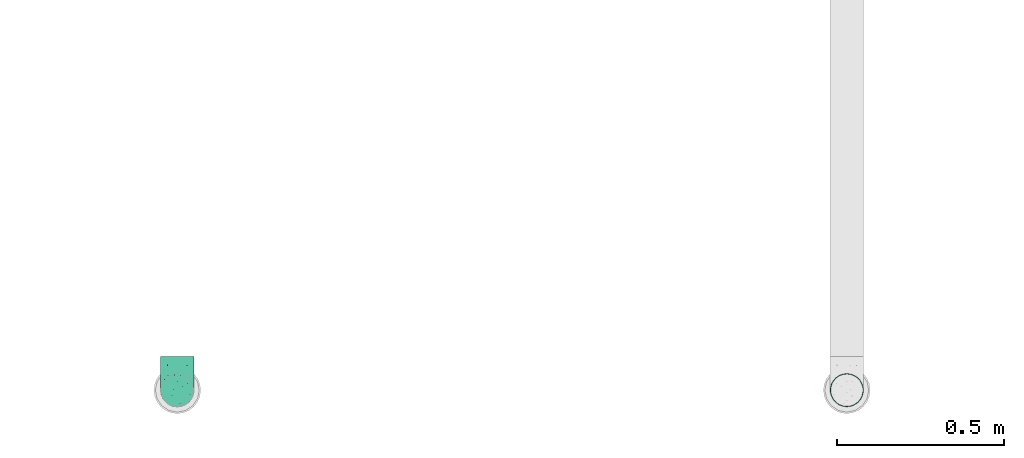
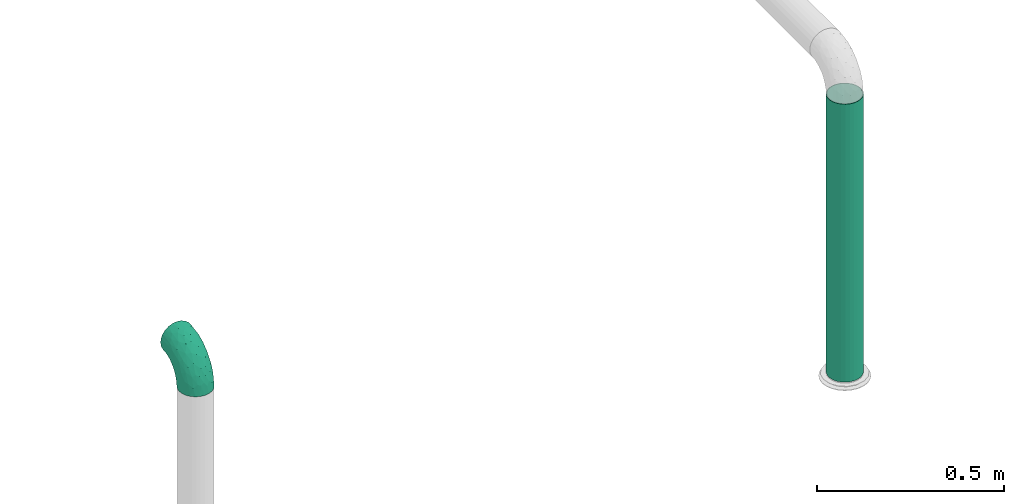
# One storey, part 19 of 103: 1 flow fitting, 1 flow segment.
"""IFC2X3 building model written with IfcOpenShell, lengths in millimetres."""

from ifc_helpers import new_model, entity, si_unit, converted_unit, derived_unit, direction, frame, origin_with_axes, origin_2d_with_axis, place, context, subcontext, project, spatial, hollow_circle, extrude, open_shell, surface_model, source, transform, mapped, material, layer, layer_set, layer_usage, type_object, element, save


model = new_model("IFC2X3")

# Units and contexts
model_context = context("Model", 3, precision=1e-05, world=origin_with_axes(), true_north=direction((0.0, 1.0)))
body_context = subcontext(model_context, "Body", "Model", "MODEL_VIEW")
ifc_project = project(units=[si_unit("AREAUNIT", "SQUARE_METRE"), si_unit("VOLUMEUNIT", "CUBIC_METRE", prefix="DECI"), si_unit("TIMEUNIT", "SECOND"), si_unit("THERMODYNAMICTEMPERATUREUNIT", "DEGREE_CELSIUS"), si_unit("PRESSUREUNIT", "PASCAL"), si_unit("MASSUNIT", "GRAM", prefix="KILO"), si_unit("LENGTHUNIT", "METRE", prefix="MILLI"), si_unit("POWERUNIT", "WATT"), si_unit("ELECTRICCURRENTUNIT", "AMPERE"), si_unit("ELECTRICVOLTAGEUNIT", "VOLT"), derived_unit("VOLUMETRICFLOWRATEUNIT", [(si_unit("VOLUMEUNIT", "CUBIC_METRE", prefix="DECI"), 1), (si_unit("TIMEUNIT", "SECOND"), -1)]), derived_unit("LINEARVELOCITYUNIT", [(si_unit("LENGTHUNIT", "METRE"), 1), (si_unit("TIMEUNIT", "SECOND"), -1)]), derived_unit("MASSDENSITYUNIT", [(si_unit("MASSUNIT", "GRAM", prefix="KILO"), 1), (si_unit("VOLUMEUNIT", "CUBIC_METRE"), -1)]), converted_unit("PLANEANGLEUNIT", "DEGREE", entity("IfcRatioMeasure", 0.01745), si_unit("PLANEANGLEUNIT", "RADIAN"), dimensions=[0, 0, 0, 0, 0, 0, 0])], contexts=[model_context])

# Site, building, storey
site_placement = place(None, origin_with_axes())
site = spatial("IfcSite", under=ifc_project, at=site_placement, CompositionType="ELEMENT")
building_placement = place(site_placement, origin_with_axes())
building = spatial("IfcBuilding", under=site, at=building_placement, Name="mc-building", CompositionType="ELEMENT")
storey_placement = place(building_placement, frame((0.0, 0.0, 5900.0), z_axis=(0.0, 0.0, 1.0), x_axis=(1.0, 0.0, 0.0)))
storey = spatial("IfcBuildingStorey", under=building, at=storey_placement, Name="3. Korrus", CompositionType="ELEMENT", Elevation=5900.0)

# Flow fitting
duct_fitting_type = type_object("IfcDuctFittingType", Name="BU", PredefinedType="BEND")
shared_shape_1 = source(origin_with_axes(), body_context, "Body", "SurfaceModel", [
    surface_model("IfcShellBasedSurfaceModel", [(-100.0, 0.0, -50.0), (-100.0, -12.94095, -48.29629), (-100.0, 12.94095, -48.29629), (-100.0, 48.29629, 12.94095), (-100.0, 25.0, -43.30127), (-100.0, 43.30127, -25.0), (-100.0, 35.35534, -35.35534), (-100.0, -50.0, 0.0), (-100.0, -48.29629, 12.94095), (-100.0, -35.35534, -35.35534), (-100.0, -25.0, -43.30127), (-100.0, -48.29629, -12.94095), (-100.0, -43.30127, -25.0), (-100.0, 48.29629, -12.94095), (-100.0, 43.30127, 25.0), (-100.0, 35.35534, 35.35534), (-100.0, -12.94095, 48.29629), (-100.0, 25.0, 43.30127), (-100.0, 12.94095, 48.29629), (-100.0, -43.30127, 25.0), (-100.0, -35.35534, 35.35534), (-100.0, -25.0, 43.30127), (-100.0, 0.0, 50.0), (-100.0, 50.0, 0.0), (-12.94095, 100.0, -48.29629), (-50.0, 100.0, 0.0), (0.0, 100.0, -50.0), (-25.0, 100.0, -43.30127), (-35.35534, 100.0, -35.35534), (-43.30127, 100.0, -25.0), (35.35534, 100.0, -35.35534), (48.29629, 100.0, 12.94095), (25.0, 100.0, -43.30127), (12.94095, 100.0, -48.29629), (43.30127, 100.0, -25.0), (48.29629, 100.0, -12.94095), (50.0, 100.0, 0.0), (-48.29629, 100.0, -12.94095), (-48.29629, 100.0, 12.94095), (-43.30127, 100.0, 25.0), (-35.35534, 100.0, 35.35534), (0.0, 100.0, 50.0), (-25.0, 100.0, 43.30127), (-12.94095, 100.0, 48.29629), (43.30127, 100.0, 25.0), (35.35534, 100.0, 35.35534), (25.0, 100.0, 43.30127), (12.94095, 100.0, 48.29629), (-58.37939, 44.26324, 39.66767), (-69.67318, 34.70921, 41.41807), (-54.95374, 29.60867, 47.22379), (-69.0983, 4.89435, 50.0), (-81.95957, 10.85813, 49.17398), (-71.45436, 24.34004, 46.19398), (-63.80701, 16.86512, 49.12211), (-68.68567, 49.28345, 29.46598), (-84.79657, 41.61468, 30.43807), (-87.38486, 20.12422, 46.19398), (-19.0983, 41.22148, 50.0), (-16.69326, 64.07661, 49.13167), (-29.12893, 54.21835, 47.49497), (-58.07867, 67.98053, 16.35576), (-67.87621, 57.34916, 18.11021), (-57.82431, 60.07162, 27.24983), (-90.54273, 47.92896, 16.84479), (-84.64671, 51.44953, 9.54872), (-89.28706, 52.13093, 0.0), (-48.57141, 84.18266, 19.13417), (-80.49866, 49.85236, 19.13417), (-10.78328, 82.03604, 49.18466), (-4.89435, 69.0983, 50.0), (-52.13093, 89.28706, 0.0), (-51.49654, 84.66157, 9.29171), (-41.22148, 19.0983, 50.0), (-40.55308, 40.55308, 47.39468), (-84.25895, 32.24248, 39.66767), (-20.22969, 86.73423, 46.19398), (-32.70712, 82.37816, 39.66767), (-39.73574, 63.26064, 40.42863), (-24.76101, 70.36257, 46.19398), (-52.07527, 72.10209, 22.70672), (-53.34351, 76.64659, 14.58596), (-75.39343, 54.87419, 11.74349), (-45.34852, 49.56196, 42.93091), (-67.79776, 60.76145, 8.68857), (-41.23466, 86.33892, 30.43807), (-53.80602, 80.86583, 0.0), (-46.83364, 71.48109, 30.43807), (-59.22534, 72.75524, 0.0), (-51.32111, 56.42251, 36.03223), (-80.86583, 53.80602, 0.0), (-64.64466, 64.64466, 0.0), (-72.75524, 59.22534, 0.0), (-86.30081, 41.24353, -30.43807), (-84.6487, 51.45583, -9.51467), (-90.59087, 47.99544, -16.6365), (-82.00387, 32.80624, -39.66767), (-72.72667, 42.3343, -34.47953), (-69.0983, 4.89435, -50.0), (-66.13967, 17.89682, -48.73206), (-41.22148, 19.0983, -50.0), (-19.92688, 59.20071, -48.9627), (-4.89435, 69.0983, -50.0), (-19.0983, 41.22148, -50.0), (-32.19887, 84.44786, -39.66767), (-82.82099, 10.02515, -49.28938), (-41.61468, 84.79657, -30.43807), (-82.27704, 21.1002, -46.19398), (-64.48049, 30.28903, -45.01594), (-71.3903, 57.59661, -10.6727), (-22.65007, 76.4146, -46.19398), (-80.71765, 49.76775, -19.13417), (-63.27201, 52.13514, -30.43807), (-66.69474, 56.78794, -20.8562), (-57.71875, 61.44646, -25.88117), (-51.44953, 84.64671, -9.54872), (-49.85236, 80.49866, -19.13417), (-49.18799, 68.95983, -29.38061), (-52.50869, 28.2692, -48.00802), (-47.92896, 90.54273, -16.84479), (-11.48103, 81.33005, -49.0827), (-31.33477, 60.4193, -45.4939), (-39.98518, 39.98518, -47.65708), (-59.80479, 65.98498, -16.07996), (-63.94971, 39.6845, -40.19955), (-52.24546, 47.26788, -40.83149), (-55.20497, 74.81068, -11.71424), (-38.49923, 67.49589, -39.66767), (-52.04722, 57.72873, -34.6201), (-73.59404, 48.69992, -26.65479), (-47.57173, 4.1387, -49.13473), (29.5722, 42.84907, -27.71428), (13.52969, 19.02651, -30.72245), (13.59601, 32.77977, -38.42312), (27.49134, 63.71843, -37.951), (17.59627, 59.41659, -43.64098), (-63.95523, -42.22253, -17.81382), (-42.84907, -29.5722, -27.71428), (-25.90272, -27.798, -14.9099), (-4.1387, 47.57173, -49.13473), (-20.45037, 20.45037, -48.41225), (-68.61243, -10.20497, -47.82471), (-73.92917, -46.87327, -9.07697), (-73.47057, -38.0442, -29.22414), (-63.71843, -27.49134, -37.951), (-32.77977, -13.59601, -38.42312), (-8.32573, -9.86545, -25.36336), (-59.41659, -17.59627, -43.64098), (10.20497, 68.61244, -47.82471), (3.58524, 39.93936, -45.93923), (-12.17948, 12.17948, -43.75507), (-39.93936, -3.58524, -45.93923), (44.88888, 61.17714, 0.0), (38.05536, 43.47505, -9.02401), (45.64165, 67.74269, -9.06645), (17.21028, 10.65055, -15.96581), (-25.0, -29.90381, 0.0), (-1.12135, -11.13977, -11.07369), (38.0442, 73.47057, -29.22414), (32.46004, 37.55825, -18.52941), (42.22253, 63.95523, -17.81382), (29.90381, 25.0, 0.0), (6.06602, -6.06602, 0.0), (-61.17714, -44.88888, 0.0), (-45.78423, -39.05041, -8.65056), (-4.97501, 4.97501, -36.29915), (-63.95523, -42.22253, 17.81382), (-67.74269, -45.64165, 9.06645), (-37.55825, -32.46004, 18.52941), (-42.84907, -29.5722, 27.71428), (-73.47057, -38.0442, 29.22414), (-4.1387, 47.57173, 49.13473), (10.20497, 68.61244, 47.82471), (-39.93936, -3.58524, 45.93923), (-59.41659, -17.59627, 43.64098), (-32.77977, -13.59601, 38.42312), (-63.71843, -27.49134, 37.951), (-10.65055, -17.21028, 15.96581), (27.798, 25.90272, 14.9099), (11.13977, 1.12135, 11.07369), (46.87327, 73.92917, 9.07697), (39.05041, 45.78423, 8.65056), (-68.61243, -10.20497, 47.82471), (-47.57173, 4.1387, 49.13473), (3.58524, 39.93936, 45.93923), (-20.45037, 20.45037, 48.41225), (-12.17948, 12.17948, 43.75507), (9.86545, 8.32574, 25.36336), (-19.02651, -13.52969, 30.72245), (-43.47505, -38.05536, 9.02401), (29.5722, 42.84907, 27.71428), (42.22253, 63.95523, 17.81382), (38.0442, 73.47057, 29.22414), (27.49134, 63.71843, 37.951), (17.59627, 59.41659, 43.64098), (13.59601, 32.77977, 38.42312), (-4.97501, 4.97501, 36.29915)], [open_shell([[[0, 1, 2]], [[2, 3, 4]], [[5, 6, 3]], [[3, 6, 4]], [[2, 7, 8]], [[9, 7, 10]], [[1, 10, 7]], [[11, 7, 12]], [[9, 12, 7]], [[7, 2, 1]], [[13, 5, 3]], [[14, 3, 2]], [[15, 14, 2]], [[16, 17, 2]], [[15, 2, 17]], [[18, 17, 16]], [[8, 19, 2]], [[2, 19, 20]], [[2, 20, 21]], [[16, 2, 21]], [[16, 22, 18]], [[23, 13, 3]], [[24, 25, 26]], [[27, 25, 24]], [[25, 28, 29]], [[27, 28, 25]], [[30, 26, 31]], [[26, 30, 32]], [[32, 33, 26]], [[30, 31, 34]], [[35, 34, 31]], [[35, 31, 36]], [[37, 25, 29]], [[26, 38, 39]], [[26, 39, 40]], [[41, 40, 42]], [[40, 41, 26]], [[41, 42, 43]], [[26, 44, 31]], [[45, 44, 26]], [[46, 45, 26]], [[47, 46, 26]], [[47, 26, 41]], [[26, 25, 38]], [[48, 49, 50]], [[22, 51, 52]], [[53, 54, 50]], [[55, 56, 49]], [[56, 14, 15]], [[18, 57, 17]], [[58, 59, 60]], [[61, 62, 63]], [[3, 64, 65]], [[53, 52, 54]], [[3, 65, 66]], [[67, 39, 38]], [[56, 68, 64]], [[65, 64, 68]], [[69, 59, 70]], [[38, 71, 72]], [[73, 58, 74]], [[75, 49, 56]], [[76, 69, 43]], [[53, 57, 52]], [[77, 78, 79]], [[42, 76, 43]], [[43, 69, 41]], [[55, 68, 56]], [[15, 17, 75]], [[76, 77, 79]], [[80, 67, 81]], [[62, 82, 68]], [[60, 78, 83]], [[62, 84, 82]], [[85, 77, 40]], [[81, 67, 72]], [[86, 72, 71]], [[87, 85, 67]], [[61, 81, 88]], [[77, 42, 40]], [[78, 77, 87]], [[15, 75, 56]], [[83, 89, 48]], [[85, 40, 39]], [[62, 68, 55]], [[89, 87, 63]], [[83, 48, 50]], [[57, 75, 17]], [[49, 75, 53]], [[67, 85, 39]], [[87, 77, 85]], [[63, 62, 55]], [[89, 55, 48]], [[80, 63, 87]], [[66, 65, 90]], [[66, 23, 3]], [[84, 91, 92]], [[92, 90, 82]], [[65, 82, 90]], [[61, 84, 62]], [[92, 82, 84]], [[68, 82, 65]], [[3, 14, 64]], [[56, 64, 14]], [[38, 25, 71]], [[81, 72, 86]], [[38, 72, 67]], [[91, 61, 88]], [[80, 81, 61]], [[63, 80, 61]], [[67, 80, 87]], [[77, 76, 42]], [[79, 59, 69]], [[79, 69, 76]], [[41, 69, 70]], [[60, 59, 79]], [[58, 70, 59]], [[78, 60, 79]], [[58, 60, 74]], [[52, 57, 18]], [[75, 57, 53]], [[22, 52, 18]], [[52, 51, 54]], [[51, 73, 54]], [[50, 73, 74]], [[73, 50, 54]], [[50, 74, 83]], [[60, 83, 74]], [[89, 83, 78]], [[87, 89, 78]], [[55, 89, 63]], [[50, 49, 53]], [[55, 49, 48]], [[81, 86, 88]], [[91, 84, 61]], [[6, 5, 93]], [[90, 94, 66]], [[13, 94, 95]], [[96, 93, 97]], [[98, 99, 100]], [[96, 4, 6]], [[101, 102, 103]], [[28, 27, 104]], [[2, 105, 0]], [[104, 106, 28]], [[99, 105, 107]], [[108, 107, 96]], [[90, 109, 94]], [[107, 2, 4]], [[13, 66, 94]], [[27, 24, 110]], [[109, 111, 94]], [[112, 113, 114]], [[37, 115, 71]], [[116, 106, 117]], [[99, 118, 100]], [[116, 115, 119]], [[37, 119, 115]], [[24, 120, 110]], [[121, 110, 101]], [[119, 106, 116]], [[101, 110, 120]], [[122, 103, 100]], [[117, 123, 116]], [[124, 125, 108]], [[115, 116, 126]], [[106, 29, 28]], [[26, 102, 120]], [[127, 104, 110]], [[97, 124, 96]], [[125, 122, 118]], [[128, 127, 125]], [[96, 6, 93]], [[115, 126, 86]], [[117, 106, 127]], [[111, 113, 129]], [[95, 93, 5]], [[97, 129, 112]], [[110, 104, 27]], [[106, 104, 127]], [[96, 107, 4]], [[99, 107, 108]], [[99, 108, 118]], [[105, 99, 98]], [[112, 114, 128]], [[121, 125, 127]], [[13, 23, 66]], [[109, 90, 92]], [[94, 111, 95]], [[91, 123, 109]], [[129, 113, 112]], [[93, 95, 111]], [[5, 13, 95]], [[71, 115, 86]], [[71, 25, 37]], [[123, 91, 88]], [[126, 116, 123]], [[123, 88, 126]], [[86, 126, 88]], [[37, 29, 119]], [[106, 119, 29]], [[129, 93, 111]], [[124, 112, 125]], [[0, 105, 98]], [[107, 105, 2]], [[125, 118, 108]], [[100, 118, 122]], [[93, 129, 97]], [[113, 111, 109]], [[109, 123, 113]], [[114, 123, 117]], [[123, 114, 113]], [[128, 114, 117]], [[127, 128, 117]], [[112, 128, 125]], [[103, 122, 101]], [[110, 121, 127]], [[101, 122, 121]], [[125, 121, 122]], [[26, 120, 24]], [[101, 120, 102]], [[96, 124, 108]], [[92, 91, 109]], [[112, 124, 97]], [[100, 130, 98]], [[131, 132, 133]], [[32, 134, 135]], [[136, 137, 138]], [[139, 140, 103]], [[98, 141, 0]], [[142, 11, 136]], [[143, 144, 137]], [[7, 11, 142]], [[137, 145, 146]], [[144, 147, 145]], [[143, 136, 12]], [[12, 136, 11]], [[9, 143, 12]], [[148, 149, 139]], [[9, 10, 144]], [[10, 1, 147]], [[130, 141, 98]], [[103, 140, 100]], [[148, 135, 149]], [[150, 151, 140]], [[152, 153, 154]], [[130, 140, 151]], [[148, 26, 33]], [[147, 1, 141]], [[155, 146, 132]], [[156, 138, 157]], [[134, 30, 158]], [[150, 140, 149]], [[158, 30, 34]], [[30, 134, 32]], [[153, 159, 160]], [[131, 160, 159]], [[144, 145, 137]], [[36, 152, 154]], [[146, 138, 137]], [[155, 161, 162]], [[158, 160, 131]], [[133, 149, 135]], [[156, 163, 164]], [[163, 142, 164]], [[139, 103, 102]], [[153, 152, 161]], [[34, 35, 160]], [[162, 157, 155]], [[132, 165, 133]], [[157, 146, 155]], [[140, 130, 100]], [[141, 130, 151]], [[141, 151, 147]], [[141, 1, 0]], [[102, 26, 148]], [[140, 139, 149]], [[102, 148, 139]], [[135, 33, 32]], [[151, 150, 145]], [[10, 147, 144]], [[151, 145, 147]], [[145, 165, 146]], [[135, 148, 33]], [[133, 135, 134]], [[131, 133, 134]], [[133, 165, 150]], [[133, 150, 149]], [[145, 150, 165]], [[132, 131, 159]], [[146, 165, 132]], [[160, 158, 34]], [[134, 158, 131]], [[144, 143, 9]], [[136, 143, 137]], [[155, 153, 161]], [[154, 153, 160]], [[153, 155, 159]], [[132, 159, 155]], [[160, 35, 154]], [[36, 154, 35]], [[164, 136, 138]], [[7, 142, 163]], [[136, 164, 142]], [[156, 164, 138]], [[156, 157, 162]], [[146, 157, 138]], [[19, 8, 166]], [[7, 163, 167]], [[168, 169, 166]], [[166, 169, 170]], [[171, 172, 70]], [[173, 174, 175]], [[21, 176, 174]], [[177, 156, 162]], [[176, 20, 170]], [[170, 20, 19]], [[161, 178, 179]], [[152, 180, 181]], [[182, 173, 183]], [[22, 16, 182]], [[184, 185, 186]], [[183, 185, 73]], [[183, 73, 51]], [[177, 187, 188]], [[189, 168, 166]], [[187, 178, 190]], [[20, 176, 21]], [[161, 152, 181]], [[44, 191, 31]], [[44, 45, 192]], [[192, 191, 44]], [[180, 36, 31]], [[193, 194, 195]], [[46, 47, 194]], [[193, 195, 190]], [[193, 45, 46]], [[172, 41, 70]], [[185, 58, 73]], [[189, 163, 156]], [[163, 189, 167]], [[70, 58, 171]], [[184, 171, 185]], [[169, 188, 175]], [[180, 31, 191]], [[192, 193, 190]], [[191, 190, 178]], [[182, 174, 173]], [[194, 47, 172]], [[190, 195, 187]], [[186, 185, 173]], [[162, 179, 177]], [[188, 196, 175]], [[179, 187, 177]], [[185, 171, 58]], [[172, 171, 184]], [[172, 184, 194]], [[172, 47, 41]], [[51, 22, 182]], [[185, 183, 173]], [[51, 182, 183]], [[174, 16, 21]], [[184, 186, 195]], [[46, 194, 193]], [[184, 195, 194]], [[195, 196, 187]], [[174, 182, 16]], [[175, 174, 176]], [[169, 175, 176]], [[175, 196, 186]], [[175, 186, 173]], [[195, 186, 196]], [[188, 169, 168]], [[187, 196, 188]], [[166, 170, 19]], [[176, 170, 169]], [[193, 192, 45]], [[191, 192, 190]], [[177, 189, 156]], [[167, 189, 166]], [[189, 177, 168]], [[188, 168, 177]], [[166, 8, 167]], [[7, 167, 8]], [[181, 191, 178]], [[36, 180, 152]], [[191, 181, 180]], [[161, 181, 178]], [[161, 179, 162]], [[187, 179, 178]]])]),
])
flow_fitting_placement = place(storey_placement, frame((11390.97051, 573.88887, 3215.0), z_axis=(-1.0, 0.0, 0.0), x_axis=(0.0, 0.0, 1.0)))
element("IfcFlowFitting", 1, at=flow_fitting_placement, inside=storey, type_object=duct_fitting_type, Name="BU", context=body_context, shape_type="MappedRepresentation", body=[
    mapped(shared_shape_1, transform((0.0, 0.0, 0.0), scale=1.0)),
])

# Flow segment
ifc_material = material(Name="FZ1")
ifc_layer = layer(ifc_material, 0.0)
ifc_layer_set = layer_set([ifc_layer], Name="FZ1")
ifc_layer_usage = layer_usage(ifc_layer_set, "AXIS1", "POSITIVE", 0.0)
duct_segment_type = type_object("IfcDuctSegmentType", Name="Safe", PredefinedType="RIGIDSEGMENT")
shared_shape_2 = source(origin_with_axes(), body_context, "Body", "SweptSolid", [
    extrude(hollow_circle(Radius=50.0, WallThickness=2.0, at=origin_2d_with_axis()), frame((0.0, 0.0, 0.0), z_axis=(1.0, 0.0, 0.0), x_axis=(0.0, 1.0, 0.0)), (0.0, 0.0, 1.0), 906.0),
])
flow_segment_placement = place(storey_placement, frame((13392.97051, 573.88887, 2461.97044), z_axis=(1.0, 0.0, 0.0), x_axis=(0.0, 0.0, 1.0)))
element("IfcFlowSegment", 2, at=flow_segment_placement, inside=storey, type_object=duct_segment_type, material=ifc_layer_usage, Name="Safe", context=body_context, shape_type="MappedRepresentation", body=[
    mapped(shared_shape_2, transform((0.0, 0.0, 0.0), scale=1.0)),
])

save(model, "model.ifc")
